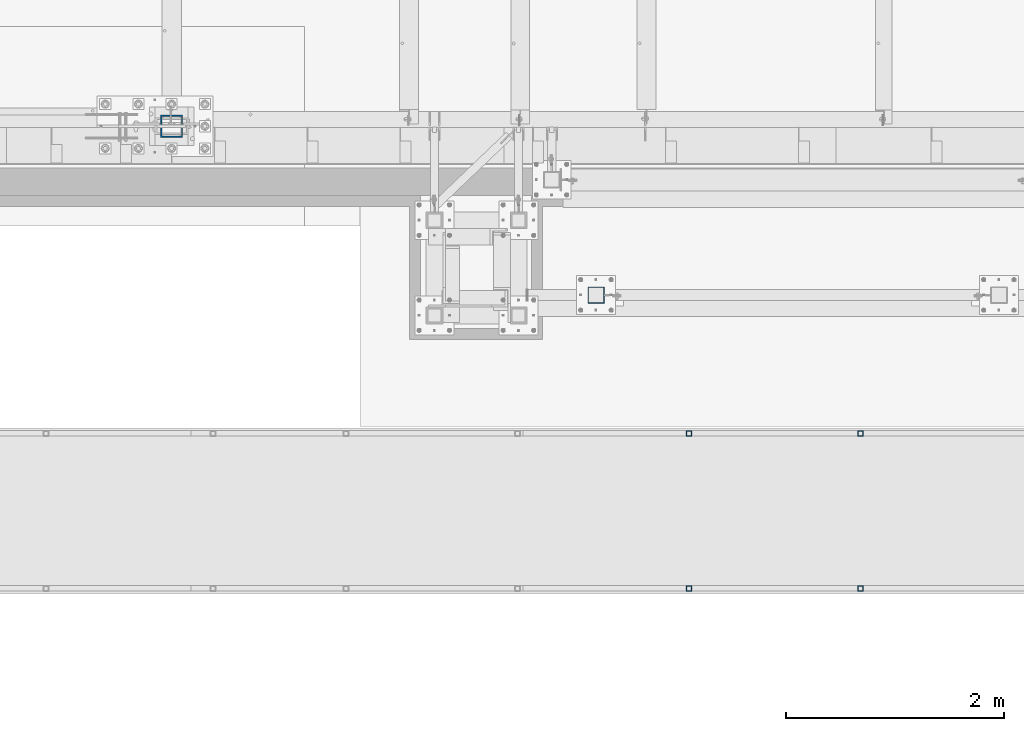
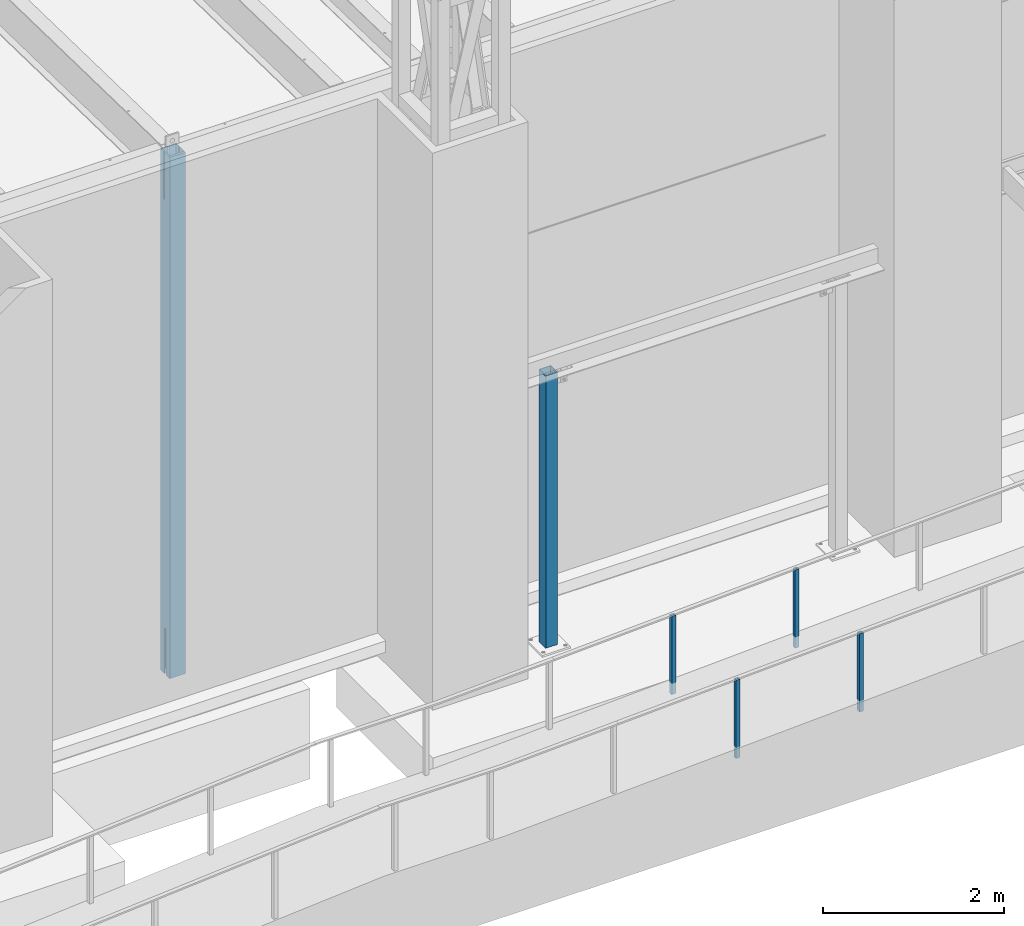
# One storey, part 879 of 1763: 6 columns, 4 elements without a shape of their own.
"""IFC2X3 building model written with IfcOpenShell, lengths in millimetres."""

from ifc_helpers import new_model, si_unit, frame, origin_with_axes, place, context, subcontext, project, spatial, faceted_brep, material, type_object, element, aggregate, save


model = new_model("IFC2X3")

# Units and contexts
model_context = context("Model", 3, precision=1e-05, world=origin_with_axes())
body_context = subcontext(model_context, "Body", "Model", "MODEL_VIEW")
ifc_project = project(units=[si_unit("LENGTHUNIT", "METRE", prefix="MILLI"), si_unit("AREAUNIT", "SQUARE_METRE"), si_unit("VOLUMEUNIT", "CUBIC_METRE"), si_unit("MASSUNIT", "GRAM", prefix="KILO"), si_unit("TIMEUNIT", "SECOND"), si_unit("PLANEANGLEUNIT", "RADIAN"), si_unit("SOLIDANGLEUNIT", "STERADIAN"), si_unit("THERMODYNAMICTEMPERATUREUNIT", "DEGREE_CELSIUS"), si_unit("LUMINOUSINTENSITYUNIT", "LUMEN")], contexts=[model_context])

# Site, building, storey
site_placement = place(None, origin_with_axes())
site = spatial("IfcSite", under=ifc_project, at=site_placement, CompositionType="ELEMENT")
building_placement = place(site_placement, origin_with_axes())
building = spatial("IfcBuilding", under=site, at=building_placement, Name="Undefined", CompositionType="ELEMENT")
storey_placement = place(building_placement, origin_with_axes())
storey = spatial("IfcBuildingStorey", under=building, at=storey_placement, Name="Undefined", CompositionType="ELEMENT", Elevation=0.0)

# Assembly, columns
assembly_1_placement = place(storey_placement, origin_with_axes())
assembly_1 = element("IfcElementAssembly", 1, at=assembly_1_placement, inside=storey, Name="HANDRAIL", AssemblyPlace="NOTDEFINED", PredefinedType="RIGID_FRAME")
ifc_material = material()
column_type_1 = type_object("IfcColumnType", Name="2X2X3/16 SQUARE TUBE SS", PredefinedType="NOTDEFINED")
column_1_placement = place(assembly_1_placement, frame((-66166.5013374895, -16535.4002326199, 4963.31904223015), z_axis=(-0.999999999891248, 0.0, 1.47479999968709e-05), x_axis=(1.47479999970212e-05, 0.0, 0.999999999891248)))
column_1 = element("IfcColumn", 2, at=column_1_placement, type_object=column_type_1, material=ifc_material, Name="POST TUBE", ObjectType="2X2X3/16 SQUARE TUBE SS", context=body_context, shape_type="Brep", body=[
    faceted_brep([(0.0, 20.6375000000007, -20.6374999999971), (0.0, -20.6375000000007, -20.6374999999971), (1058.23349084755, -20.6375000000007, -20.6375000024054), (1058.23349084755, 20.6375000000007, -20.6375000024054), (0.0, -20.6375000000007, 20.6374999999971), (1056.26220687483, -20.6375000000007, 20.6374999975815), (0.0, 20.6375000000007, 20.6374999999971), (1056.26220687483, 20.6375000000007, 20.6374999975815), (-1.45519152283669e-11, 25.4000000000015, -25.3999999999869), (1.45519152283669e-11, 25.4000000000015, 25.3999999999796), (1056.03475103182, 25.4000000000015, 25.3999999975786), (1058.46094669056, 25.4000000000015, -25.4000000024098), (0.0, -25.4000000000015, 25.3999999999942), (1056.03475103182, -25.4000000000015, 25.3999999975786), (-1.45519152283669e-11, -25.4000000000015, -25.3999999999869), (1058.46094669056, -25.4000000000015, -25.4000000024098)], [[[0, 1, 2, 3]], [[1, 4, 5, 2]], [[4, 6, 7, 5]], [[6, 0, 3, 7]], [[8, 9, 10, 11]], [[9, 12, 13, 10]], [[12, 14, 15, 13]], [[14, 8, 11, 15]], [[13, 15, 11, 10], [5, 7, 3, 2]], [[14, 12, 9, 8], [6, 4, 1, 0]]]),
])
column_2_placement = place(assembly_1_placement, frame((-67741.2997756593, -16535.4002326199, 4888.13032791702), z_axis=(-0.999999999891248, 0.0, 1.47479999968709e-05), x_axis=(1.47479999970212e-05, 0.0, 0.999999999891248)))
column_2 = element("IfcColumn", 3, at=column_2_placement, type_object=column_type_1, material=ifc_material, Name="POST TUBE", ObjectType="2X2X3/16 SQUARE TUBE SS", context=body_context, shape_type="Brep", body=[
    faceted_brep([(0.0, 20.6375000000007, -20.6374999999971), (0.0, -20.6375000000007, -20.6374999999971), (1058.23349084755, -20.6375000000007, -20.6375000024054), (1058.23349084755, 20.6375000000007, -20.6375000024054), (0.0, -20.6375000000007, 20.6374999999971), (1056.26220687483, -20.6375000000007, 20.6374999975815), (0.0, 20.6375000000007, 20.6374999999971), (1056.26220687483, 20.6375000000007, 20.6374999975815), (-1.45519152283669e-11, 25.4000000000015, -25.3999999999869), (1.45519152283669e-11, 25.4000000000015, 25.3999999999796), (1056.03475103182, 25.4000000000015, 25.3999999975786), (1058.46094669056, 25.4000000000015, -25.4000000024098), (0.0, -25.4000000000015, 25.3999999999942), (1056.03475103182, -25.4000000000015, 25.3999999975786), (-1.45519152283669e-11, -25.4000000000015, -25.3999999999869), (1058.46094669056, -25.4000000000015, -25.4000000024098)], [[[0, 1, 2, 3]], [[1, 4, 5, 2]], [[4, 6, 7, 5]], [[6, 0, 3, 7]], [[8, 9, 10, 11]], [[9, 12, 13, 10]], [[12, 14, 15, 13]], [[14, 8, 11, 15]], [[13, 15, 11, 10], [5, 7, 3, 2]], [[14, 12, 9, 8], [6, 4, 1, 0]]]),
])
aggregate(assembly_1, [column_1, column_2])

assembly_2_placement = place(storey_placement, origin_with_axes())
assembly_2 = element("IfcElementAssembly", 4, at=assembly_2_placement, inside=storey, Name="HANDRAIL", AssemblyPlace="NOTDEFINED", PredefinedType="RIGID_FRAME")
column_3_placement = place(assembly_2_placement, frame((-66166.5013374895, -17957.80011631, 4963.31904223015), z_axis=(-0.999999999891248, 0.0, 1.47479999968709e-05), x_axis=(1.47479999970212e-05, 0.0, 0.999999999891248)))
column_3 = element("IfcColumn", 5, at=column_3_placement, type_object=column_type_1, material=ifc_material, Name="POST TUBE", ObjectType="2X2X3/16 SQUARE TUBE SS", context=body_context, shape_type="Brep", body=[
    faceted_brep([(0.0, 20.6375000000007, -20.6374999999971), (0.0, -20.6375000000007, -20.6374999999971), (1058.23349084755, -20.6375000000007, -20.6375000024054), (1058.23349084755, 20.6375000000007, -20.6375000024054), (0.0, -20.6375000000007, 20.6374999999971), (1056.26220687483, -20.6375000000007, 20.6374999975815), (0.0, 20.6375000000007, 20.6374999999971), (1056.26220687483, 20.6375000000007, 20.6374999975815), (-1.45519152283669e-11, 25.4000000000015, -25.3999999999869), (1.45519152283669e-11, 25.4000000000015, 25.3999999999796), (1056.03475103182, 25.4000000000015, 25.3999999975786), (1058.46094669056, 25.4000000000015, -25.4000000024098), (0.0, -25.4000000000015, 25.3999999999942), (1056.03475103182, -25.4000000000015, 25.3999999975786), (-1.45519152283669e-11, -25.4000000000015, -25.3999999999869), (1058.46094669056, -25.4000000000015, -25.4000000024098)], [[[0, 1, 2, 3]], [[1, 4, 5, 2]], [[4, 6, 7, 5]], [[6, 0, 3, 7]], [[8, 9, 10, 11]], [[9, 12, 13, 10]], [[12, 14, 15, 13]], [[14, 8, 11, 15]], [[13, 15, 11, 10], [5, 7, 3, 2]], [[14, 12, 9, 8], [6, 4, 1, 0]]]),
])
column_4_placement = place(assembly_2_placement, frame((-67741.2997756593, -17957.80011631, 4888.13032791702), z_axis=(-0.999999999891248, 0.0, 1.47479999968709e-05), x_axis=(1.47479999970212e-05, 0.0, 0.999999999891248)))
column_4 = element("IfcColumn", 6, at=column_4_placement, type_object=column_type_1, material=ifc_material, Name="POST TUBE", ObjectType="2X2X3/16 SQUARE TUBE SS", context=body_context, shape_type="Brep", body=[
    faceted_brep([(0.0, 20.6375000000007, -20.6374999999971), (0.0, -20.6375000000007, -20.6374999999971), (1058.23349084755, -20.6375000000007, -20.6375000024054), (1058.23349084755, 20.6375000000007, -20.6375000024054), (0.0, -20.6375000000007, 20.6374999999971), (1056.26220687483, -20.6375000000007, 20.6374999975815), (0.0, 20.6375000000007, 20.6374999999971), (1056.26220687483, 20.6375000000007, 20.6374999975815), (-1.45519152283669e-11, 25.4000000000015, -25.3999999999869), (1.45519152283669e-11, 25.4000000000015, 25.3999999999796), (1056.03475103182, 25.4000000000015, 25.3999999975786), (1058.46094669056, 25.4000000000015, -25.4000000024098), (0.0, -25.4000000000015, 25.3999999999942), (1056.03475103182, -25.4000000000015, 25.3999999975786), (-1.45519152283669e-11, -25.4000000000015, -25.3999999999869), (1058.46094669056, -25.4000000000015, -25.4000000024098)], [[[0, 1, 2, 3]], [[1, 4, 5, 2]], [[4, 6, 7, 5]], [[6, 0, 3, 7]], [[8, 9, 10, 11]], [[9, 12, 13, 10]], [[12, 14, 15, 13]], [[14, 8, 11, 15]], [[13, 15, 11, 10], [5, 7, 3, 2]], [[14, 12, 9, 8], [6, 4, 1, 0]]]),
])
aggregate(assembly_2, [column_3, column_4])

# Assembly, column
assembly_3_placement = place(storey_placement, origin_with_axes())
assembly_3 = element("IfcElementAssembly", 7, at=assembly_3_placement, inside=storey, Name="COLUMN", AssemblyPlace="NOTDEFINED", PredefinedType="RIGID_FRAME")
column_type_2 = type_object("IfcColumnType", Name="HSS6X6X1/4", PredefinedType="NOTDEFINED")
column_5_placement = place(assembly_3_placement, frame((-68595.3116892775, -15265.4000613784, 5029.2), z_axis=(0.0, 1.0, 0.0), x_axis=(0.0, 0.0, 1.0)))
column_5 = element("IfcColumn", 8, at=column_5_placement, type_object=column_type_2, material=ifc_material, Name="COLUMN", ObjectType="HSS6X6X1/4", context=body_context, shape_type="Brep", body=[
    faceted_brep([(63.4999999999973, 69.8499999999985, -69.8500000000004), (63.4999999999973, -69.8499999999985, -69.8500000000004), (3740.15, -69.8499999999985, -69.8500000000004), (3740.15, 69.8499999999985, -69.8500000000004), (63.4999999999973, -69.8499999999985, 69.8500000000004), (3740.15, -69.8499999999985, 69.8500000000004), (63.4999999999973, 69.8499999999985, 69.8500000000004), (3740.15, 69.8499999999985, 69.8500000000004), (63.4999999999973, 76.1999999999971, -76.2000000000007), (63.4999999999973, 76.1999999999971, 76.2000000000007), (3740.15, 76.1999999999971, 76.2000000000007), (3740.15, 76.1999999999971, -76.2000000000007), (63.4999999999973, -76.1999999999971, 76.2000000000007), (3740.15, -76.1999999999971, 76.2000000000007), (63.4999999999973, -76.1999999999971, -76.2000000000007), (3740.15, -76.1999999999971, -76.2000000000007)], [[[0, 1, 2, 3]], [[1, 4, 5, 2]], [[4, 6, 7, 5]], [[6, 0, 3, 7]], [[8, 9, 10, 11]], [[9, 12, 13, 10]], [[12, 14, 15, 13]], [[14, 8, 11, 15]], [[13, 15, 11, 10], [5, 7, 3, 2]], [[14, 12, 9, 8], [6, 4, 1, 0]]]),
])
aggregate(assembly_3, [column_5])

assembly_4_placement = place(storey_placement, origin_with_axes())
assembly_4 = element("IfcElementAssembly", 9, at=assembly_4_placement, inside=storey, Name="COLUMN", AssemblyPlace="NOTDEFINED", PredefinedType="RIGID_FRAME")
column_type_3 = type_object("IfcColumnType", Name="HSS8X8X1/2", PredefinedType="NOTDEFINED")
column_6_placement = place(assembly_4_placement, frame((-72491.0372736984, -13716.0, 5029.2), z_axis=(0.0, 1.0, 0.0), x_axis=(0.0, 0.0, 1.0)))
column_6 = element("IfcColumn", 10, at=column_6_placement, type_object=column_type_3, material=ifc_material, Name="COLUMN", ObjectType="HSS8X8X1/2", context=body_context, shape_type="Brep", body=[
    faceted_brep([(7150.10000000001, 88.8999999999942, 10.3189310014568), (7137.40000000001, 101.600000000006, 10.3189310014568), (6510.33751239778, 101.600000000006, 10.3189310014568), (6510.33751239778, 88.8999999999942, 10.3189310014568), (6506.08494268263, 101.600000000006, 11.1648197109444), (6506.08494268263, 88.8999999999942, 11.1648197109444), (6502.47978815697, 101.600000000006, 13.5737069513871), (6502.47978815697, 88.8999999999942, 13.5737069513871), (6500.07090091653, 101.600000000006, 17.178861477043), (6500.07090091653, 88.8999999999942, 17.178861477043), (6499.22501220704, 101.600000000006, 21.4314311921917), (6499.22501220704, 88.8999999999942, 21.4314311921917), (6500.07090091653, 101.600000000006, 25.6840009073403), (6500.07090091653, 88.8999999999942, 25.6840009073403), (6502.47978815697, 101.600000000006, 29.2891554329963), (6502.47978815697, 88.8999999999942, 29.2891554329963), (6506.08494268263, 101.600000000006, 31.698042673439), (6506.08494268263, 88.8999999999942, 31.698042673439), (6510.33751239778, 101.600000000006, 32.5439313829265), (6510.33751239778, 88.8999999999942, 32.5439313829265), (7150.10000000001, 88.8999999999942, 32.5439313829265), (7137.40000000001, 101.600000000006, 32.5439313829265), (101.599999999999, 88.9000000000015, 14.2875007629391), (101.599999999999, 101.599999999999, 14.2875007629391), (713.240502002579, 101.600000000006, 14.2875007629355), (713.240502002579, 88.8999999999942, 14.2875007629355), (718.100581520624, 101.600000000006, 13.3207708403479), (718.100581520624, 88.8999999999942, 13.3207708403479), (722.220757988778, 101.600000000006, 10.5677569398704), (722.220757988778, 88.8999999999942, 10.5677569398704), (724.973771889257, 101.600000000006, 6.44758047171672), (724.973771889257, 88.8999999999942, 6.44758047171672), (725.940501811844, 101.600000000006, 1.58750095367031), (725.940501811844, 88.8999999999942, 1.58750095367031), (725.940501811844, 101.600000000006, -1.58750019073887), (725.940501811844, 88.8999999999942, -1.58750019073887), (724.973771889257, 101.600000000006, -6.44757970878527), (724.973771889257, 88.8999999999942, -6.44757970878527), (722.220757988778, 101.600000000006, -10.5677561769389), (722.220757988778, 88.8999999999942, -10.5677561769389), (718.100581520624, 101.600000000006, -13.3207700774165), (718.100581520624, 88.8999999999942, -13.3207700774165), (713.240502002579, 101.600000000006, -14.287500000004), (713.240502002579, 88.8999999999942, -14.287500000004), (101.599999999999, 101.599999999999, -14.2875000000004), (101.599999999999, 88.9000000000015, -14.2875000000004), (6595.26045414009, -15.8749998092535, 88.8999999999996), (6595.26045414009, -15.8749998092535, 101.6), (7137.40000000001, -15.8749990520446, 101.6), (7150.10000000001, -15.8749990520446, 88.8999999999996), (6592.83041438106, -15.3916348479543, 88.8999999999996), (6592.83041438106, -15.3916348479543, 101.6), (6590.77032614699, -14.0151278977137, 88.8999999999996), (6590.77032614699, -14.0151278977137, 101.6), (6589.39381919675, -11.9550396636478, 88.8999999999996), (6589.39381919675, -11.9550396636478, 101.6), (6588.91045423546, -9.52499990462093, 88.8999999999996), (6588.91045423546, -9.52499990462093, 101.6), (6589.39381919675, -7.09496014559409, 88.8999999999996), (6589.39381919675, -7.09496014559409, 101.6), (6590.77032614699, -5.03487191152817, 88.8999999999996), (6590.77032614699, -5.03487191152817, 101.6), (6592.83041438106, -3.65836496128759, 88.8999999999996), (6592.83041438106, -3.65836496128759, 101.6), (6595.26045414009, -3.17499999998836, 88.8999999999996), (6595.26045414009, -3.17499999998836, 101.6), (7150.10000000001, -3.17499924277945, 88.8999999999996), (7137.40000000001, -3.17499924277945, 101.6), (7137.40000000001, 101.599999999999, 101.6), (101.599999999999, 101.599999999999, 101.6), (101.599999999999, -101.599999999999, 101.6), (7137.40000000001, -101.599999999999, 101.6), (101.599999999999, 88.9000000000015, -88.8999999999996), (101.599999999999, -88.9000000000015, -88.8999999999996), (7150.10000000001, -88.9000000000015, -88.8999999999996), (7150.10000000001, 88.9000000000015, -88.8999999999996), (101.599999999999, -101.599999999999, -101.6), (101.599999999999, 101.599999999999, -101.6), (7137.40000000001, 101.599999999999, -101.6), (7137.40000000001, -101.599999999999, -101.6), (7150.10000000001, -88.8999999999942, 10.3189310014568), (7137.40000000001, -101.600000000006, 10.3189310014568), (6510.33750019074, -88.8999999999942, 10.3189310014568), (6510.33750019074, -101.600000000006, 10.3189310014568), (6506.08493047559, -88.8999999999942, 11.1648197109444), (6506.08493047559, -101.600000000006, 11.1648197109444), (6502.47977594993, -88.8999999999942, 13.5737069513871), (6502.47977594993, -101.600000000006, 13.5737069513871), (6500.07088870949, -88.8999999999942, 17.178861477043), (6500.07088870949, -101.600000000006, 17.178861477043), (6499.225, -88.8999999999942, 21.4314311921917), (6499.225, -101.600000000006, 21.4314311921917), (6500.07088870949, -88.8999999999942, 25.6840009073403), (6500.07088870949, -101.600000000006, 25.6840009073403), (6502.47977594993, -88.8999999999942, 29.2891554329963), (6502.47977594993, -101.600000000006, 29.2891554329963), (6506.08493047559, -88.8999999999942, 31.698042673439), (6506.08493047559, -101.600000000006, 31.698042673439), (101.599999999999, -101.599999999999, 14.2875007629391), (713.240502002579, -101.600000000006, 14.2875007629355), (718.100581520624, -101.600000000006, 13.3207708403479), (722.220757988778, -101.600000000006, 10.5677569398704), (724.973771889257, -101.600000000006, 6.44758047171672), (725.940501811844, -101.600000000006, 1.58750095367031), (725.940501811844, -101.600000000006, -1.58750019073887), (724.973771889257, -101.600000000006, -6.44757970878527), (722.220757988778, -101.600000000006, -10.5677561769389), (718.100581520624, -101.600000000006, -13.3207700774165), (713.240502002579, -101.600000000006, -14.287500000004), (101.599999999999, -101.599999999999, -14.2875000000004), (6510.33750019074, -101.600000000006, 32.5439313829265), (7137.40000000001, -101.600000000006, 32.5439313829265), (101.599999999999, -88.9000000000015, -14.2875000000004), (713.240502002579, -88.8999999999942, -14.287500000004), (718.100581520624, -88.8999999999942, -13.3207700774165), (722.220757988778, -88.8999999999942, -10.5677561769389), (724.973771889257, -88.8999999999942, -6.44757970878527), (725.940501811844, -88.8999999999942, -1.58750019073887), (725.940501811844, -88.8999999999942, 1.58750095367031), (724.973771889257, -88.8999999999942, 6.44758047171672), (722.220757988778, -88.8999999999942, 10.5677569398704), (718.100581520624, -88.8999999999942, 13.3207708403479), (713.240502002579, -88.8999999999942, 14.2875007629355), (101.599999999999, -88.9000000000015, 14.2875007629391), (101.599999999999, 88.9000000000015, 88.8999999999996), (101.599999999999, -88.9000000000015, 88.8999999999996), (7150.10000000001, -88.9000000000015, 88.8999999999996), (7150.10000000001, -88.8999999999942, 32.5439313829265), (6510.33750019074, -88.8999999999942, 32.5439313829265), (7150.10000000001, 88.9000000000015, 88.8999999999996)], [[[0, 1, 2, 3]], [[3, 2, 4, 5]], [[5, 4, 6, 7]], [[7, 6, 8, 9]], [[9, 8, 10, 11]], [[11, 10, 12, 13]], [[13, 12, 14, 15]], [[15, 14, 16, 17]], [[17, 16, 18, 19]], [[20, 19, 18, 21]], [[22, 23, 24, 25]], [[25, 24, 26, 27]], [[27, 26, 28, 29]], [[29, 28, 30, 31]], [[31, 30, 32, 33]], [[33, 32, 34, 35]], [[35, 34, 36, 37]], [[37, 36, 38, 39]], [[39, 38, 40, 41]], [[41, 40, 42, 43]], [[43, 42, 44, 45]], [[46, 47, 48, 49]], [[47, 46, 50, 51]], [[51, 50, 52, 53]], [[53, 52, 54, 55]], [[55, 54, 56, 57]], [[57, 56, 58, 59]], [[59, 58, 60, 61]], [[61, 60, 62, 63]], [[63, 62, 64, 65]], [[65, 64, 66, 67]], [[47, 51, 53, 55, 57, 59, 61, 63, 65, 67, 68, 69, 70, 71, 48]], [[72, 73, 74, 75]], [[76, 77, 78, 79]], [[74, 79, 78, 75]], [[79, 74, 80, 81]], [[80, 82, 83, 81]], [[83, 82, 84, 85]], [[85, 84, 86, 87]], [[87, 86, 88, 89]], [[89, 88, 90, 91]], [[91, 90, 92, 93]], [[93, 92, 94, 95]], [[95, 94, 96, 97]], [[71, 70, 98, 99, 100, 101, 102, 103, 104, 105, 106, 107, 108, 109, 76, 79, 81, 83, 85, 87, 89, 91, 93, 95, 97, 110, 111]], [[73, 72, 45, 44, 77, 76, 109, 112]], [[108, 113, 112, 109]], [[107, 114, 113, 108]], [[106, 115, 114, 107]], [[105, 116, 115, 106]], [[104, 117, 116, 105]], [[103, 118, 117, 104]], [[102, 119, 118, 103]], [[101, 120, 119, 102]], [[100, 121, 120, 101]], [[99, 122, 121, 100]], [[98, 123, 122, 99]], [[70, 69, 23, 22, 124, 125, 123, 98]], [[96, 94, 92, 90, 88, 86, 84, 82, 80, 74, 73, 112, 113, 114, 115, 116, 117, 118, 119, 120, 121, 122, 123, 125, 126, 127, 128]], [[97, 96, 128, 110]], [[127, 111, 110, 128]], [[126, 71, 111, 127]], [[49, 48, 71, 126]], [[125, 124, 129, 66, 64, 62, 60, 58, 56, 54, 52, 50, 46, 49, 126]], [[67, 66, 129, 68]], [[68, 129, 20, 21]], [[16, 14, 12, 10, 8, 6, 4, 2, 1, 78, 77, 44, 42, 40, 38, 36, 34, 32, 30, 28, 26, 24, 23, 69, 68, 21, 18]], [[75, 78, 1, 0]], [[129, 124, 22, 25, 27, 29, 31, 33, 35, 37, 39, 41, 43, 45, 72, 75, 0, 3, 5, 7, 9, 11, 13, 15, 17, 19, 20]]]),
])
aggregate(assembly_4, [column_6])

save(model, "model.ifc")
